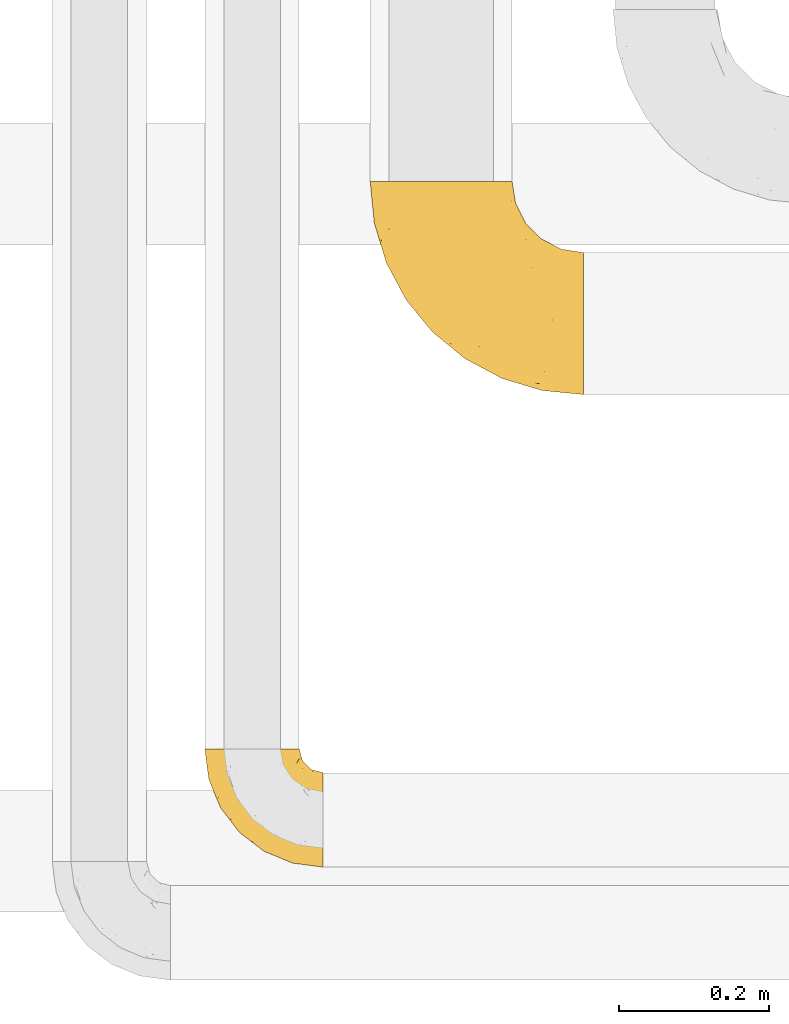
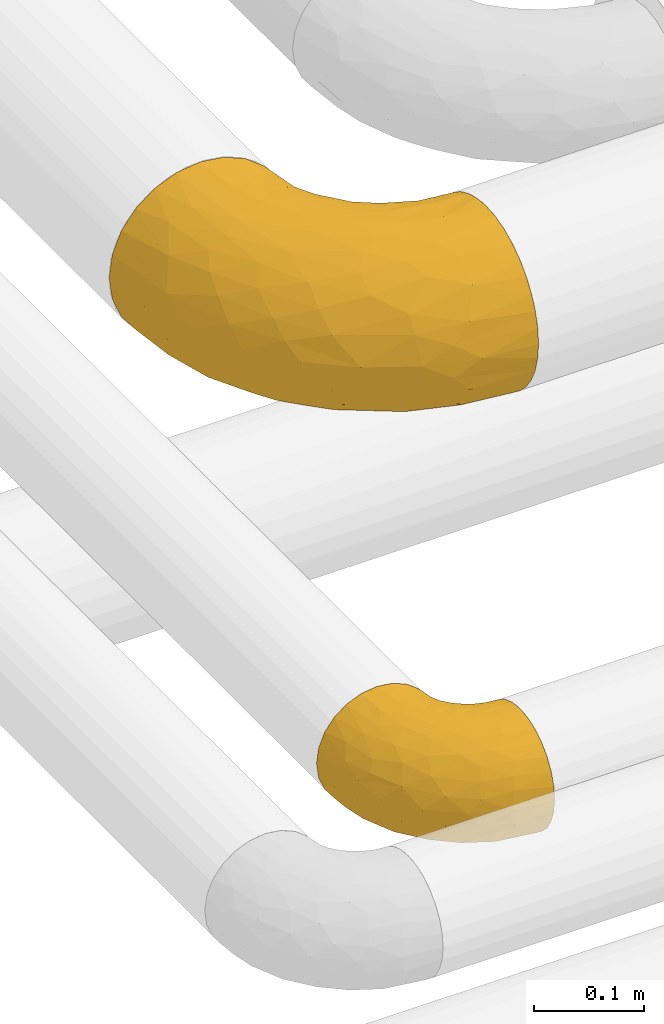
# One storey, part 101 of 827: 2 coverings.
"""IFC2X3 building model written with IfcOpenShell, lengths in millimetres."""

from ifc_helpers import new_model, entity, si_unit, converted_unit, derived_unit, direction, frame, origin, place, context, subcontext, project, spatial, faceted_brep, element, save


model = new_model("IFC2X3")

# Units and contexts
model_context = context("Model", 3, precision=0.01, world=origin(), true_north=direction((6.12303176911189e-17, 1.0)))
body_context = subcontext(model_context, "Body", "Model", "MODEL_VIEW")
ifc_project = project(units=[si_unit("LENGTHUNIT", "METRE", prefix="MILLI"), si_unit("AREAUNIT", "SQUARE_METRE"), si_unit("VOLUMEUNIT", "CUBIC_METRE"), converted_unit("PLANEANGLEUNIT", "DEGREE", entity("IfcRatioMeasure", 0.0174532925199433), si_unit("PLANEANGLEUNIT", "RADIAN"), dimensions=[0, 0, 0, 0, 0, 0, 0]), si_unit("MASSUNIT", "GRAM", prefix="KILO"), derived_unit("MASSDENSITYUNIT", [(si_unit("MASSUNIT", "GRAM", prefix="KILO"), 1), (si_unit("LENGTHUNIT", "METRE"), -3)]), derived_unit("MOMENTOFINERTIAUNIT", [(si_unit("LENGTHUNIT", "METRE"), 4)]), si_unit("TIMEUNIT", "SECOND"), si_unit("FREQUENCYUNIT", "HERTZ"), si_unit("THERMODYNAMICTEMPERATUREUNIT", "DEGREE_CELSIUS"), derived_unit("THERMALTRANSMITTANCEUNIT", [(si_unit("MASSUNIT", "GRAM", prefix="KILO"), 1), (si_unit("THERMODYNAMICTEMPERATUREUNIT", "KELVIN"), -1), (si_unit("TIMEUNIT", "SECOND"), -3)]), derived_unit("VOLUMETRICFLOWRATEUNIT", [(si_unit("LENGTHUNIT", "METRE"), 3), (si_unit("TIMEUNIT", "SECOND"), -1)]), derived_unit("MASSFLOWRATEUNIT", [(si_unit("MASSUNIT", "GRAM", prefix="KILO"), 1), (si_unit("TIMEUNIT", "SECOND"), -1)]), derived_unit("ROTATIONALFREQUENCYUNIT", [(si_unit("TIMEUNIT", "SECOND"), -1)]), si_unit("ELECTRICCURRENTUNIT", "AMPERE"), si_unit("ELECTRICVOLTAGEUNIT", "VOLT"), si_unit("POWERUNIT", "WATT"), si_unit("FORCEUNIT", "NEWTON", prefix="KILO"), si_unit("ILLUMINANCEUNIT", "LUX"), si_unit("LUMINOUSFLUXUNIT", "LUMEN"), si_unit("LUMINOUSINTENSITYUNIT", "CANDELA"), derived_unit("USERDEFINED", [(si_unit("MASSUNIT", "GRAM", prefix="KILO"), -1), (si_unit("LENGTHUNIT", "METRE"), -2), (si_unit("TIMEUNIT", "SECOND"), 3), (si_unit("LUMINOUSFLUXUNIT", "LUMEN"), 1)]), derived_unit("LINEARVELOCITYUNIT", [(si_unit("LENGTHUNIT", "METRE"), 1), (si_unit("TIMEUNIT", "SECOND"), -1)]), si_unit("PRESSUREUNIT", "PASCAL"), derived_unit("USERDEFINED", [(si_unit("LENGTHUNIT", "METRE"), -2), (si_unit("MASSUNIT", "GRAM", prefix="KILO"), 1), (si_unit("TIMEUNIT", "SECOND"), -2)]), derived_unit("LINEARFORCEUNIT", [(si_unit("MASSUNIT", "GRAM", prefix="KILO"), 1), (si_unit("LENGTHUNIT", "METRE"), 1), (si_unit("TIMEUNIT", "SECOND"), -2), (si_unit("LENGTHUNIT", "METRE"), -1)]), derived_unit("PLANARFORCEUNIT", [(si_unit("MASSUNIT", "GRAM", prefix="KILO"), 1), (si_unit("LENGTHUNIT", "METRE"), 1), (si_unit("TIMEUNIT", "SECOND"), -2), (si_unit("LENGTHUNIT", "METRE"), -2)])], contexts=[model_context])

# Site, building, storey
site_placement = place(None, origin())
site = spatial("IfcSite", under=ifc_project, at=site_placement, CompositionType="ELEMENT")
building_placement = place(site_placement, origin())
building = spatial("IfcBuilding", under=site, at=building_placement, CompositionType="ELEMENT")
storey_placement = place(building_placement, frame((0.0, 0.0, 28200.0)))
storey = spatial("IfcBuildingStorey", under=building, at=storey_placement, Name="08", CompositionType="ELEMENT", Elevation=28200.0)

# Coverings
covering_1_placement = place(storey_placement, frame((26802.99, 6351.92, 3035.35)))
element("IfcCovering", 1, at=covering_1_placement, inside=storey, Name=":ADSK_", ObjectType=":ADSK_", PredefinedType="INSULATION", context=body_context, shape_type="Brep", body=[
    faceted_brep([(159.65, 50.62, 126.11), (159.65, 37.29, 121.45), (159.65, 25.34, 113.94), (159.65, 15.35, 103.96), (159.65, 7.84, 92.0), (159.65, 3.18, 78.68), (159.65, 1.6, 64.65), (159.65, 3.18, 50.62), (159.65, 7.84, 37.29), (159.65, 15.35, 25.34), (159.65, 25.33, 15.35), (159.65, 37.29, 7.84), (159.65, 50.61, 3.18), (159.65, 64.65, 1.6), (159.65, 78.67, 3.18), (159.65, 92.0, 7.84), (159.65, 103.95, 15.35), (159.65, 113.94, 25.33), (159.65, 121.45, 37.29), (159.65, 126.11, 50.61), (159.65, 127.7, 64.65), (159.65, 126.11, 78.67), (159.65, 121.45, 92.0), (159.65, 113.94, 103.95), (159.65, 103.96, 113.94), (159.65, 92.0, 121.45), (159.65, 78.68, 126.11), (159.65, 64.65, 127.7), (127.7, 159.65, 64.65), (125.55, 159.65, 48.33), (119.25, 159.65, 33.12), (109.23, 159.65, 20.06), (96.17, 159.65, 10.04), (80.96, 159.65, 3.74), (75.35, 159.65, 3.01), (64.65, 159.65, 1.6), (48.33, 159.65, 3.74), (33.12, 159.65, 10.04), (20.06, 159.65, 20.06), (10.04, 159.65, 33.12), (3.74, 159.65, 48.33), (1.6, 159.65, 64.65), (3.74, 159.65, 80.96), (10.04, 159.65, 96.17), (20.06, 159.65, 109.23), (33.12, 159.65, 119.25), (48.33, 159.65, 125.55), (64.65, 159.65, 127.7), (75.35, 159.65, 126.29), (80.96, 159.65, 125.55), (96.17, 159.65, 119.25), (109.23, 159.65, 109.23), (119.25, 159.65, 96.17), (125.55, 159.65, 80.96), (16.01, 131.11, 101.1), (10.29, 121.84, 86.72), (24.76, 98.59, 98.7), (4.94, 132.73, 75.93), (6.98, 118.74, 64.65), (87.32, 45.67, 113.39), (62.3, 62.3, 111.06), (58.52, 49.95, 96.87), (36.35, 65.74, 84.07), (22.77, 80.62, 64.65), (47.89, 47.89, 64.65), (40.91, 117.53, 119.56), (42.82, 90.48, 112.75), (57.25, 98.53, 122.85), (51.19, 128.08, 125.08), (66.64, 107.83, 126.64), (98.56, 30.59, 105.78), (94.44, 23.56, 93.81), (123.53, 14.41, 96.07), (20.12, 94.66, 87.11), (12.95, 103.54, 75.77), (28.48, 121.36, 111.99), (118.74, 6.98, 64.65), (121.88, 9.17, 83.58), (65.08, 35.7, 80.96), (92.08, 18.43, 78.34), (98.53, 57.25, 122.85), (81.84, 81.84, 125.88), (72.43, 72.43, 120.97), (134.31, 56.38, 126.67), (129.11, 43.86, 122.64), (82.79, 103.81, 127.7), (76.04, 117.05, 127.7), (69.29, 130.29, 127.7), (129.58, 21.28, 107.12), (115.86, 34.21, 115.07), (42.36, 74.07, 102.81), (103.81, 82.79, 127.7), (98.55, 88.04, 127.7), (93.3, 93.3, 127.7), (147.25, 66.61, 127.7), (138.77, 67.95, 127.7), (130.29, 69.29, 127.7), (107.83, 66.64, 126.64), (117.05, 76.04, 127.7), (80.62, 22.77, 64.65), (66.61, 147.25, 127.7), (121.29, 120.78, 113.05), (128.09, 128.88, 101.81), (118.04, 132.53, 108.46), (79.47, 145.71, 126.21), (94.94, 132.18, 122.65), (86.01, 121.21, 126.55), (94.69, 115.88, 125.45), (83.06, 134.78, 126.01), (104.39, 113.68, 123.3), (107.01, 124.96, 118.99), (148.3, 105.67, 113.51), (143.82, 116.22, 104.6), (134.19, 103.69, 118.04), (116.87, 149.68, 101.6), (111.58, 142.04, 109.98), (122.36, 151.17, 92.1), (124.16, 140.2, 96.28), (94.28, 145.72, 121.05), (128.25, 147.4, 79.4), (146.72, 128.57, 79.19), (134.92, 136.38, 80.39), (138.87, 126.93, 93.14), (133.28, 79.77, 126.75), (121.77, 89.98, 125.71), (145.83, 79.6, 126.17), (143.67, 131.98, 64.65), (139.93, 90.59, 123.28), (153.63, 129.31, 64.65), (132.32, 133.25, 91.58), (132.59, 119.53, 107.1), (126.42, 111.1, 116.28), (102.97, 143.67, 116.32), (149.52, 123.62, 90.34), (120.88, 100.76, 122.74), (131.98, 143.67, 64.65), (96.12, 104.28, 126.77), (115.84, 112.26, 119.84), (108.2, 103.95, 124.71), (110.85, 92.99, 126.47), (122.36, 151.17, 37.19), (118.35, 144.66, 27.66), (128.25, 147.4, 49.9), (66.61, 147.25, 1.6), (146.72, 128.57, 50.1), (134.92, 136.38, 48.89), (110.73, 93.43, 2.88), (121.83, 100.15, 6.55), (121.77, 89.98, 3.58), (82.79, 103.81, 1.6), (76.04, 117.05, 1.6), (86.01, 121.21, 2.74), (134.19, 103.69, 11.25), (124.9, 110.23, 11.93), (132.35, 118.45, 21.09), (83.06, 134.78, 3.28), (94.94, 132.18, 6.64), (102.97, 143.67, 12.97), (111.58, 142.04, 19.31), (121.29, 120.78, 16.23), (118.82, 132.4, 21.44), (128.68, 127.76, 26.96), (94.28, 145.72, 8.24), (79.47, 145.71, 3.08), (107.01, 124.96, 10.3), (149.51, 123.62, 38.95), (124.16, 140.2, 33.01), (147.25, 66.61, 1.6), (138.77, 67.95, 1.6), (138.87, 126.93, 36.15), (143.82, 116.21, 24.69), (139.92, 90.59, 6.01), (133.28, 79.77, 2.54), (148.3, 105.66, 15.78), (130.29, 69.29, 1.6), (145.83, 79.6, 3.12), (131.94, 133.38, 37.33), (103.81, 82.79, 1.6), (117.05, 76.04, 1.6), (96.12, 104.28, 2.52), (94.69, 115.88, 3.84), (104.39, 113.68, 5.99), (114.83, 112.97, 9.35), (93.3, 93.3, 1.6), (108.2, 103.94, 4.58), (69.29, 130.29, 1.6), (24.76, 98.59, 30.59), (16.01, 131.11, 28.19), (28.48, 121.36, 17.3), (40.91, 117.53, 9.73), (10.29, 121.84, 42.57), (12.23, 105.45, 53.51), (4.91, 132.83, 53.42), (66.64, 107.83, 2.65), (134.31, 56.38, 2.62), (129.11, 43.85, 6.66), (98.53, 57.25, 6.44), (65.08, 35.7, 48.33), (58.52, 49.95, 32.42), (94.45, 23.55, 35.49), (107.83, 66.64, 2.65), (81.84, 81.84, 3.41), (51.19, 128.08, 4.21), (20.8, 92.46, 43.07), (98.56, 30.58, 23.52), (129.58, 21.27, 22.18), (131.93, 12.64, 33.1), (87.32, 45.66, 15.9), (115.86, 34.21, 14.23), (42.82, 90.48, 16.54), (36.35, 65.74, 45.22), (57.25, 98.53, 6.44), (72.43, 72.43, 8.33), (62.3, 62.3, 18.23), (38.39, 72.15, 32.99), (22.86, 82.52, 53.35), (92.06, 19.03, 48.76), (121.88, 9.17, 45.72)], [[[0, 1, 2, 3, 4, 5, 6, 7, 8, 9, 10, 11, 12, 13, 14, 15, 16, 17, 18, 19, 20, 21, 22, 23, 24, 25, 26, 27]], [[28, 29, 30, 31, 32, 33, 34, 35, 36, 37, 38, 39, 40, 41, 42, 43, 44, 45, 46, 47, 48, 49, 50, 51, 52, 53]], [[54, 55, 56]], [[57, 41, 58]], [[59, 60, 61]], [[62, 63, 64]], [[65, 66, 67]], [[68, 67, 69]], [[70, 71, 72]], [[55, 73, 56]], [[43, 42, 55]], [[55, 74, 73]], [[44, 75, 45]], [[44, 43, 54]], [[76, 5, 77]], [[71, 78, 79]], [[45, 75, 65]], [[46, 68, 47]], [[80, 81, 82]], [[0, 83, 84]], [[69, 85, 86, 87]], [[69, 81, 85]], [[84, 1, 0]], [[2, 88, 3]], [[4, 3, 72]], [[44, 54, 75]], [[5, 4, 77]], [[89, 2, 1]], [[72, 3, 88]], [[5, 76, 6]], [[70, 88, 89]], [[68, 65, 67]], [[88, 2, 89]], [[56, 90, 66]], [[64, 78, 62]], [[81, 91, 92, 93, 85]], [[83, 27, 94, 95, 96]], [[62, 61, 90]], [[97, 96, 98, 91]], [[80, 97, 81]], [[42, 57, 55]], [[62, 78, 61]], [[84, 89, 1]], [[78, 64, 99]], [[57, 74, 55]], [[76, 77, 79]], [[77, 72, 71]], [[82, 81, 67]], [[97, 83, 96]], [[80, 89, 84]], [[79, 78, 99]], [[71, 70, 61]], [[81, 97, 91]], [[83, 80, 84]], [[68, 87, 100, 47]], [[81, 69, 67]], [[68, 69, 87]], [[65, 46, 45]], [[65, 68, 46]], [[66, 65, 75]], [[56, 66, 75]], [[66, 60, 82]], [[71, 61, 78]], [[60, 66, 90]], [[83, 97, 80]], [[27, 83, 0]], [[59, 70, 89]], [[70, 59, 61]], [[89, 80, 59]], [[82, 59, 80]], [[55, 54, 43]], [[75, 54, 56]], [[66, 82, 67]], [[59, 82, 60]], [[41, 57, 42]], [[74, 57, 58]], [[58, 63, 74]], [[62, 74, 63]], [[74, 62, 73]], [[62, 56, 73]], [[4, 72, 77]], [[70, 72, 88]], [[76, 79, 99]], [[71, 79, 77]], [[62, 90, 56]], [[60, 90, 61]], [[101, 102, 103]], [[100, 87, 104]], [[105, 106, 107]], [[108, 104, 87]], [[107, 109, 110]], [[108, 87, 86]], [[111, 112, 113]], [[114, 51, 115]], [[116, 114, 117]], [[51, 50, 118]], [[119, 28, 53]], [[120, 121, 122]], [[98, 123, 124]], [[125, 96, 95]], [[116, 53, 52]], [[126, 121, 120]], [[104, 108, 118]], [[98, 124, 91]], [[25, 24, 127]], [[120, 128, 126]], [[122, 129, 102]], [[95, 94, 27, 26]], [[122, 102, 130]], [[125, 127, 123]], [[24, 111, 127]], [[21, 20, 128]], [[112, 130, 131]], [[48, 47, 100, 49]], [[132, 110, 115]], [[23, 111, 24]], [[129, 119, 117]], [[120, 133, 21]], [[112, 23, 22]], [[134, 113, 131]], [[121, 126, 135]], [[133, 112, 22]], [[128, 120, 21]], [[132, 51, 118]], [[120, 122, 133]], [[119, 121, 135]], [[129, 117, 102]], [[125, 26, 25]], [[26, 125, 95]], [[127, 125, 25]], [[28, 119, 135]], [[119, 53, 116]], [[127, 113, 124]], [[96, 125, 123]], [[112, 131, 113]], [[101, 103, 110]], [[85, 93, 136]], [[124, 123, 127]], [[98, 96, 123]], [[112, 111, 23]], [[127, 111, 113]], [[112, 133, 122]], [[21, 133, 22]], [[107, 110, 105]], [[110, 109, 137]], [[86, 106, 108]], [[138, 109, 136]], [[105, 118, 108]], [[107, 106, 85]], [[104, 50, 49]], [[124, 134, 139]], [[138, 93, 92]], [[92, 91, 139]], [[100, 104, 49]], [[118, 105, 132]], [[104, 118, 50]], [[110, 132, 105]], [[51, 132, 115]], [[108, 106, 105]], [[85, 106, 86]], [[114, 116, 52]], [[119, 116, 117]], [[51, 114, 52]], [[114, 115, 103]], [[117, 114, 103]], [[130, 102, 101]], [[117, 103, 102]], [[110, 103, 115]], [[130, 101, 131]], [[122, 130, 112]], [[101, 137, 131]], [[113, 134, 124]], [[137, 134, 131]], [[124, 139, 91]], [[134, 138, 139]], [[92, 139, 138]], [[110, 137, 101]], [[134, 137, 138]], [[136, 109, 107]], [[137, 109, 138]], [[85, 136, 107]], [[138, 136, 93]], [[122, 121, 129]], [[129, 121, 119]], [[30, 140, 141]], [[30, 29, 140]], [[28, 135, 142]], [[143, 35, 34, 33]], [[19, 144, 128]], [[126, 145, 135]], [[146, 147, 148]], [[149, 150, 151]], [[152, 153, 154]], [[155, 156, 151]], [[157, 31, 158]], [[159, 160, 161]], [[32, 162, 163]], [[158, 31, 30]], [[157, 164, 156]], [[126, 144, 145]], [[126, 128, 144]], [[18, 165, 19]], [[141, 166, 160]], [[14, 13, 167, 168]], [[163, 143, 33]], [[169, 165, 170]], [[18, 17, 170]], [[153, 159, 154]], [[142, 135, 145]], [[148, 171, 172]], [[159, 161, 154]], [[171, 152, 173]], [[173, 17, 16]], [[16, 15, 171]], [[158, 160, 164]], [[174, 175, 168]], [[173, 170, 17]], [[19, 128, 20]], [[174, 172, 175]], [[165, 169, 144]], [[162, 157, 156]], [[175, 172, 171]], [[144, 169, 145]], [[176, 169, 161]], [[166, 140, 142]], [[175, 171, 15]], [[168, 175, 14]], [[14, 175, 15]], [[142, 145, 176]], [[28, 142, 29]], [[148, 177, 146]], [[148, 178, 177]], [[152, 171, 148]], [[179, 180, 181]], [[164, 180, 156]], [[174, 178, 172]], [[148, 172, 178]], [[171, 173, 16]], [[170, 173, 152]], [[19, 165, 144]], [[170, 165, 18]], [[153, 182, 159]], [[146, 183, 184]], [[181, 180, 164]], [[180, 151, 156]], [[163, 155, 185]], [[155, 150, 185]], [[162, 156, 155]], [[143, 163, 185]], [[180, 179, 149]], [[32, 163, 33]], [[163, 162, 155]], [[31, 162, 32]], [[31, 157, 162]], [[164, 157, 158]], [[149, 151, 180]], [[155, 151, 150]], [[142, 140, 29]], [[141, 140, 166]], [[176, 145, 169]], [[30, 141, 158]], [[164, 160, 159]], [[158, 141, 160]], [[166, 161, 160]], [[154, 169, 170]], [[169, 154, 161]], [[152, 154, 170]], [[147, 152, 148]], [[153, 147, 182]], [[181, 182, 184]], [[164, 159, 182]], [[161, 166, 176]], [[142, 176, 166]], [[183, 146, 177]], [[184, 182, 147]], [[184, 147, 146]], [[152, 147, 153]], [[182, 181, 164]], [[179, 184, 183]], [[184, 179, 181]], [[149, 179, 183]], [[186, 187, 188]], [[37, 36, 189]], [[190, 191, 192]], [[193, 185, 150, 149]], [[194, 195, 196]], [[197, 198, 199]], [[200, 201, 177]], [[193, 202, 185]], [[203, 190, 186]], [[202, 189, 36]], [[41, 40, 192]], [[204, 205, 199]], [[9, 8, 206]], [[187, 190, 39]], [[40, 39, 190]], [[38, 37, 188]], [[207, 208, 204]], [[202, 35, 143, 185]], [[39, 38, 187]], [[195, 11, 208]], [[201, 149, 183, 177]], [[188, 189, 209]], [[197, 64, 210]], [[186, 188, 209]], [[13, 12, 194]], [[211, 201, 212]], [[12, 11, 195]], [[193, 201, 211]], [[212, 201, 196]], [[10, 208, 11]], [[213, 214, 209]], [[64, 63, 215]], [[216, 197, 199]], [[8, 217, 206]], [[7, 217, 8]], [[203, 191, 190]], [[7, 6, 76]], [[208, 205, 204]], [[205, 10, 9]], [[199, 205, 206]], [[7, 76, 217]], [[205, 208, 10]], [[216, 76, 99]], [[200, 177, 178, 174]], [[64, 197, 99]], [[63, 58, 191]], [[208, 196, 195]], [[196, 200, 194]], [[198, 197, 210]], [[216, 199, 217]], [[201, 193, 149]], [[202, 193, 211]], [[202, 211, 189]], [[35, 202, 36]], [[211, 212, 209]], [[37, 189, 188]], [[211, 209, 189]], [[213, 198, 214]], [[200, 174, 194]], [[201, 200, 196]], [[214, 198, 210]], [[213, 207, 198]], [[194, 174, 168, 167, 13]], [[195, 194, 12]], [[198, 204, 199]], [[204, 198, 207]], [[212, 207, 213]], [[196, 208, 207]], [[188, 187, 38]], [[190, 187, 186]], [[207, 212, 196]], [[209, 212, 213]], [[214, 203, 186]], [[191, 215, 63]], [[191, 203, 215]], [[192, 191, 58]], [[41, 192, 58]], [[190, 192, 40]], [[203, 210, 215]], [[64, 215, 210]], [[199, 206, 217]], [[9, 206, 205]], [[76, 216, 217]], [[99, 197, 216]], [[203, 214, 210]], [[209, 214, 186]]]),
])
covering_2_placement = place(storey_placement, frame((27023.89, 6983.55, 3003.55)))
element("IfcCovering", 2, at=covering_2_placement, inside=storey, Name=":ADSK_", ObjectType=":ADSK_", PredefinedType="INSULATION", context=body_context, shape_type="Brep", body=[
    faceted_brep([(286.45, 128.88, 185.58), (286.45, 112.9, 189.86), (286.45, 96.45, 191.3), (286.45, 79.97, 189.85), (286.45, 64.0, 185.57), (286.45, 49.01, 178.58), (286.45, 35.47, 169.1), (286.45, 23.78, 157.41), (286.45, 14.3, 143.86), (286.45, 7.31, 128.88), (286.45, 3.03, 112.9), (286.45, 1.6, 96.45), (286.45, 3.04, 79.97), (286.45, 7.32, 64.0), (286.45, 14.31, 49.01), (286.45, 23.79, 35.47), (286.45, 35.48, 23.78), (286.45, 49.03, 14.3), (286.45, 64.02, 7.31), (286.45, 79.99, 3.03), (286.45, 96.45, 1.6), (286.45, 112.92, 3.04), (286.45, 128.89, 7.32), (286.45, 143.88, 14.31), (286.45, 157.42, 23.79), (286.45, 169.11, 35.48), (286.45, 178.59, 49.03), (286.45, 185.58, 64.02), (286.45, 189.86, 79.99), (286.45, 191.3, 96.45), (286.45, 189.85, 112.92), (286.45, 185.57, 128.89), (286.45, 178.58, 143.88), (286.45, 169.1, 157.42), (286.45, 157.41, 169.11), (286.45, 143.86, 178.59), (188.06, 286.45, 71.9), (178.59, 286.45, 49.02), (163.51, 286.45, 29.38), (143.87, 286.45, 14.3), (120.99, 286.45, 4.83), (96.45, 286.45, 1.6), (71.9, 286.45, 4.83), (49.02, 286.45, 14.3), (29.38, 286.45, 29.38), (14.3, 286.45, 49.02), (4.83, 286.45, 71.9), (1.6, 286.45, 96.45), (4.83, 286.45, 120.99), (14.3, 286.45, 143.87), (29.38, 286.45, 163.51), (49.02, 286.45, 178.59), (71.9, 286.45, 188.06), (96.45, 286.45, 191.3), (120.99, 286.45, 188.06), (143.87, 286.45, 178.59), (163.51, 286.45, 163.51), (178.59, 286.45, 143.87), (188.06, 286.45, 120.99), (191.3, 286.45, 96.45), (16.41, 207.16, 121.68), (7.07, 230.87, 96.45), (23.28, 177.44, 96.45), (244.17, 101.21, 191.3), (221.52, 75.45, 186.17), (128.19, 49.6, 96.45), (76.16, 97.11, 115.28), (85.03, 85.03, 96.45), (71.97, 110.7, 133.57), (109.4, 69.67, 126.74), (235.79, 55.92, 179.38), (43.96, 141.85, 118.18), (105.47, 85.95, 147.26), (105.66, 105.66, 164.89), (69.05, 133.88, 153.74), (61.05, 239.75, 182.37), (49.6, 128.19, 96.45), (173.27, 40.05, 145.56), (147.14, 66.09, 159.67), (173.55, 30.83, 128.04), (205.77, 15.09, 114.59), (223.05, 16.73, 134.07), (83.65, 200.13, 186.29), (115.26, 204.01, 191.3), (137.2, 137.2, 188.93), (137.9, 167.98, 191.3), (101.21, 244.17, 191.3), (51.1, 193.07, 167.18), (39.75, 245.07, 169.79), (26.72, 222.8, 151.26), (103.61, 139.8, 180.27), (158.7, 99.32, 183.96), (147.24, 84.58, 173.57), (179.14, 107.66, 189.47), (177.44, 23.28, 96.45), (230.87, 7.07, 96.45), (234.61, 32.22, 161.05), (188.67, 71.93, 179.53), (68.9, 189.6, 178.18), (204.01, 115.26, 191.3), (78.01, 148.44, 169.92), (200.11, 52.01, 170.04), (167.98, 137.9, 191.3), (42.39, 159.89, 138.7), (44.41, 177.31, 153.85), (210.04, 209.21, 145.19), (216.97, 216.97, 120.48), (196.26, 237.27, 133.57), (125.74, 250.56, 187.85), (250.61, 130.07, 186.57), (229.02, 147.73, 182.51), (204.21, 136.88, 189.31), (135.11, 227.41, 187.2), (150.51, 258.83, 176.23), (236.27, 177.74, 160.15), (262.59, 173.42, 155.16), (238.19, 189.58, 144.49), (183.11, 255.57, 143.85), (190.73, 260.47, 123.79), (253.14, 161.46, 169.37), (152.62, 225.56, 181.0), (139.69, 200.06, 189.22), (160.14, 198.27, 184.22), (172.39, 246.32, 161.43), (188.52, 228.3, 153.04), (218.68, 171.0, 172.9), (200.6, 159.3, 183.96), (200.68, 241.72, 113.68), (209.47, 230.52, 96.45), (195.95, 257.04, 96.45), (257.56, 191.27, 124.72), (233.76, 200.75, 128.11), (198.25, 195.96, 166.78), (230.52, 209.47, 96.45), (179.91, 153.24, 189.28), (153.38, 178.82, 189.4), (176.62, 216.54, 170.06), (257.04, 195.95, 96.45), (260.66, 146.91, 178.19), (264.5, 183.12, 139.77), (194.11, 179.46, 177.85), (174.93, 174.93, 185.63), (216.97, 216.97, 72.41), (218.67, 171.03, 20.01), (253.13, 161.47, 23.53), (229.0, 147.76, 10.39), (190.73, 260.47, 69.1), (200.68, 241.72, 79.21), (257.55, 191.28, 68.18), (183.11, 255.57, 49.04), (188.52, 228.3, 39.85), (172.39, 246.32, 31.47), (196.26, 237.27, 59.32), (261.32, 183.43, 52.33), (238.18, 189.59, 48.41), (115.26, 204.01, 1.6), (139.69, 200.06, 3.67), (137.9, 167.98, 1.6), (233.76, 200.76, 64.79), (160.14, 198.27, 8.68), (153.75, 178.43, 3.5), (125.74, 250.56, 5.04), (101.21, 244.17, 1.6), (127.98, 222.61, 3.55), (152.62, 225.56, 11.89), (150.51, 258.83, 16.66), (204.01, 115.26, 1.6), (250.6, 130.09, 6.33), (244.17, 101.21, 1.6), (262.59, 173.44, 37.74), (263.88, 115.04, 3.15), (210.04, 209.22, 47.7), (200.6, 159.33, 8.95), (176.62, 216.56, 22.84), (194.09, 179.49, 15.05), (167.98, 137.9, 1.6), (179.93, 153.23, 3.61), (260.66, 146.92, 14.71), (221.41, 186.29, 33.08), (204.18, 136.9, 3.58), (174.94, 174.94, 7.26), (198.23, 195.99, 26.12), (139.34, 240.72, 8.67), (90.85, 207.12, 3.96), (117.36, 164.43, 3.42), (99.32, 158.7, 8.93), (16.41, 207.16, 71.21), (228.07, 74.22, 6.5), (186.43, 70.34, 14.71), (132.6, 105.83, 14.21), (165.83, 106.52, 5.41), (164.99, 59.96, 29.31), (67.05, 106.71, 81.23), (66.18, 210.61, 11.88), (26.72, 222.8, 41.63), (42.39, 159.89, 54.19), (39.75, 245.07, 23.1), (46.14, 173.95, 38.82), (51.1, 193.07, 25.71), (105.66, 105.66, 28.0), (122.59, 74.02, 42.88), (68.39, 112.5, 63.46), (38.16, 152.02, 74.76), (70.79, 145.03, 30.2), (92.04, 139.45, 18.28), (223.06, 16.73, 58.81), (222.82, 34.37, 32.42), (236.35, 55.69, 13.57), (76.73, 117.99, 43.95), (173.55, 30.84, 64.84), (205.77, 15.09, 78.29), (109.41, 69.67, 66.14), (173.29, 40.05, 47.31)], [[[0, 1, 2, 3, 4, 5, 6, 7, 8, 9, 10, 11, 12, 13, 14, 15, 16, 17, 18, 19, 20, 21, 22, 23, 24, 25, 26, 27, 28, 29, 30, 31, 32, 33, 34, 35]], [[36, 37, 38, 39, 40, 41, 42, 43, 44, 45, 46, 47, 48, 49, 50, 51, 52, 53, 54, 55, 56, 57, 58, 59]], [[60, 61, 62]], [[61, 48, 47]], [[63, 64, 3]], [[65, 66, 67]], [[68, 66, 69]], [[70, 4, 64]], [[60, 62, 71]], [[72, 73, 74]], [[75, 52, 51]], [[76, 71, 62]], [[77, 78, 72]], [[66, 65, 69]], [[79, 80, 81]], [[52, 75, 82]], [[83, 84, 85]], [[86, 53, 52]], [[87, 88, 89]], [[80, 10, 9]], [[60, 49, 48]], [[84, 83, 82]], [[84, 90, 91]], [[86, 52, 82]], [[78, 92, 73]], [[82, 83, 86]], [[93, 84, 91]], [[94, 95, 80]], [[7, 6, 96]], [[91, 92, 97]], [[49, 89, 50]], [[78, 73, 72]], [[9, 8, 81]], [[81, 8, 96]], [[60, 89, 49]], [[81, 80, 9]], [[98, 82, 75]], [[7, 96, 8]], [[92, 90, 73]], [[95, 11, 10]], [[88, 51, 50]], [[5, 70, 6]], [[93, 64, 63]], [[99, 93, 63]], [[3, 64, 4]], [[2, 63, 3]], [[73, 100, 74]], [[80, 79, 94]], [[101, 77, 96]], [[84, 93, 102]], [[60, 103, 89]], [[102, 85, 84]], [[48, 61, 60]], [[101, 96, 70]], [[96, 6, 70]], [[90, 98, 100]], [[81, 96, 77]], [[65, 94, 79]], [[74, 104, 103]], [[90, 84, 82]], [[10, 80, 95]], [[81, 77, 79]], [[77, 69, 79]], [[65, 79, 69]], [[64, 93, 91]], [[102, 93, 99]], [[88, 75, 51]], [[75, 88, 98]], [[100, 98, 87]], [[90, 82, 98]], [[104, 74, 100]], [[90, 100, 73]], [[104, 100, 87]], [[72, 68, 69]], [[68, 74, 103]], [[77, 72, 69]], [[77, 101, 78]], [[97, 101, 70]], [[101, 92, 78]], [[90, 92, 91]], [[74, 68, 72]], [[71, 68, 103]], [[60, 71, 103]], [[66, 76, 67]], [[68, 71, 66]], [[76, 66, 71]], [[87, 89, 104]], [[89, 103, 104]], [[4, 70, 5]], [[97, 70, 64]], [[91, 97, 64]], [[101, 97, 92]], [[89, 88, 50]], [[88, 87, 98]], [[105, 106, 107]], [[54, 53, 86]], [[54, 86, 108]], [[109, 110, 111]], [[108, 112, 113]], [[114, 115, 116]], [[117, 107, 118]], [[55, 54, 108]], [[119, 115, 114]], [[120, 121, 122]], [[123, 124, 117]], [[56, 55, 113]], [[113, 123, 56]], [[125, 126, 110]], [[63, 0, 109]], [[127, 128, 129]], [[130, 131, 116]], [[58, 118, 59]], [[114, 132, 125]], [[107, 127, 118]], [[133, 128, 106]], [[115, 33, 32]], [[134, 135, 102]], [[99, 111, 102]], [[128, 127, 106]], [[105, 124, 132]], [[0, 35, 109]], [[99, 63, 109]], [[124, 136, 132]], [[2, 1, 63]], [[30, 137, 130]], [[35, 34, 138]], [[32, 31, 139]], [[1, 0, 63]], [[131, 137, 133]], [[34, 119, 138]], [[137, 30, 29]], [[116, 115, 139]], [[130, 139, 31]], [[105, 116, 131]], [[31, 30, 130]], [[115, 119, 33]], [[119, 34, 33]], [[131, 133, 106]], [[56, 123, 57]], [[110, 119, 125]], [[110, 109, 138]], [[85, 121, 83]], [[110, 138, 119]], [[111, 110, 126]], [[109, 35, 138]], [[136, 122, 140]], [[126, 140, 141]], [[86, 83, 108]], [[83, 121, 112]], [[124, 107, 117]], [[114, 105, 132]], [[129, 59, 118]], [[106, 127, 107]], [[129, 118, 127]], [[117, 58, 57]], [[58, 117, 118]], [[57, 123, 117]], [[124, 123, 136]], [[105, 107, 124]], [[123, 120, 136]], [[136, 120, 122]], [[108, 113, 55]], [[123, 113, 120]], [[140, 125, 132]], [[134, 126, 141]], [[111, 126, 134]], [[109, 111, 99]], [[125, 140, 126]], [[136, 140, 132]], [[134, 141, 135]], [[111, 134, 102]], [[131, 130, 137]], [[105, 131, 106]], [[121, 135, 122]], [[112, 121, 120]], [[135, 121, 85]], [[122, 141, 140]], [[135, 85, 102]], [[141, 122, 135]], [[116, 139, 130]], [[32, 139, 115]], [[114, 116, 105]], [[119, 114, 125]], [[113, 112, 120]], [[83, 112, 108]], [[128, 133, 142]], [[143, 144, 145]], [[59, 129, 146]], [[146, 129, 147]], [[137, 28, 148]], [[149, 150, 151]], [[142, 152, 147]], [[128, 147, 129]], [[153, 154, 148]], [[155, 156, 157]], [[133, 137, 158]], [[156, 159, 160]], [[39, 161, 40]], [[41, 40, 162]], [[156, 163, 164]], [[165, 151, 164]], [[166, 167, 168]], [[40, 161, 162]], [[25, 169, 26]], [[39, 38, 165]], [[21, 170, 22]], [[142, 158, 171]], [[153, 169, 154]], [[172, 143, 145]], [[137, 29, 28]], [[159, 173, 174]], [[175, 160, 176]], [[153, 26, 169]], [[144, 169, 25]], [[146, 149, 36]], [[24, 23, 177]], [[178, 169, 144]], [[158, 137, 148]], [[25, 24, 144]], [[38, 37, 151]], [[24, 177, 144]], [[175, 176, 179]], [[180, 172, 176]], [[167, 166, 179]], [[171, 152, 142]], [[177, 145, 144]], [[148, 154, 158]], [[21, 20, 168]], [[152, 149, 146]], [[178, 144, 143]], [[21, 168, 170]], [[167, 23, 22]], [[151, 150, 173]], [[23, 167, 177]], [[27, 148, 28]], [[145, 177, 167]], [[143, 172, 174]], [[178, 143, 181]], [[39, 165, 182]], [[162, 161, 163]], [[178, 171, 154]], [[181, 173, 150]], [[168, 167, 170]], [[167, 22, 170]], [[142, 147, 128]], [[146, 147, 152]], [[150, 149, 152]], [[146, 36, 59]], [[151, 37, 149]], [[36, 149, 37]], [[152, 171, 150]], [[181, 150, 171]], [[173, 181, 174]], [[164, 151, 173]], [[151, 165, 38]], [[182, 163, 161]], [[172, 145, 179]], [[174, 172, 180]], [[167, 179, 145]], [[175, 179, 166]], [[179, 176, 172]], [[160, 175, 157]], [[174, 180, 159]], [[143, 174, 181]], [[171, 158, 154]], [[133, 158, 142]], [[163, 156, 155]], [[159, 156, 164]], [[173, 159, 164]], [[160, 159, 180]], [[176, 160, 180]], [[156, 160, 157]], [[148, 27, 153]], [[26, 153, 27]], [[171, 178, 181]], [[169, 178, 154]], [[162, 163, 155]], [[39, 182, 161]], [[165, 164, 182]], [[164, 163, 182]], [[183, 184, 185]], [[45, 186, 46]], [[61, 46, 186]], [[183, 41, 162]], [[155, 157, 184]], [[62, 61, 186]], [[187, 166, 168]], [[188, 189, 190]], [[188, 191, 189]], [[175, 190, 184]], [[192, 67, 76]], [[42, 183, 193]], [[194, 186, 45]], [[42, 193, 43]], [[61, 47, 46]], [[186, 194, 195]], [[44, 43, 196]], [[197, 194, 198]], [[155, 183, 162]], [[199, 191, 200]], [[44, 196, 194]], [[195, 201, 202]], [[19, 187, 168]], [[62, 186, 202]], [[44, 194, 45]], [[190, 185, 184]], [[190, 175, 166]], [[196, 193, 198]], [[199, 203, 204]], [[205, 14, 13]], [[168, 20, 19]], [[18, 187, 19]], [[16, 206, 207]], [[208, 203, 199]], [[206, 16, 15]], [[41, 183, 42]], [[193, 183, 185]], [[17, 207, 18]], [[188, 190, 187]], [[209, 205, 210]], [[65, 67, 211]], [[206, 15, 205]], [[195, 208, 201]], [[209, 212, 205]], [[206, 191, 188]], [[65, 211, 209]], [[210, 12, 95]], [[210, 13, 12]], [[11, 95, 12]], [[191, 206, 212]], [[206, 188, 207]], [[205, 212, 206]], [[94, 210, 95]], [[205, 15, 14]], [[193, 185, 204]], [[207, 188, 187]], [[187, 190, 166]], [[200, 208, 199]], [[94, 65, 209]], [[210, 205, 13]], [[200, 191, 212]], [[189, 191, 199]], [[212, 211, 200]], [[211, 201, 208]], [[211, 208, 200]], [[203, 197, 198]], [[209, 210, 94]], [[211, 212, 209]], [[192, 211, 67]], [[195, 202, 186]], [[192, 202, 201]], [[62, 202, 76]], [[202, 192, 76]], [[211, 192, 201]], [[204, 189, 199]], [[185, 190, 189]], [[155, 184, 183]], [[184, 157, 175]], [[18, 207, 187]], [[207, 17, 16]], [[197, 208, 195]], [[198, 193, 204]], [[204, 203, 198]], [[189, 204, 185]], [[208, 197, 203]], [[194, 197, 195]], [[193, 196, 43]], [[194, 196, 198]]]),
])

save(model, "model.ifc")
